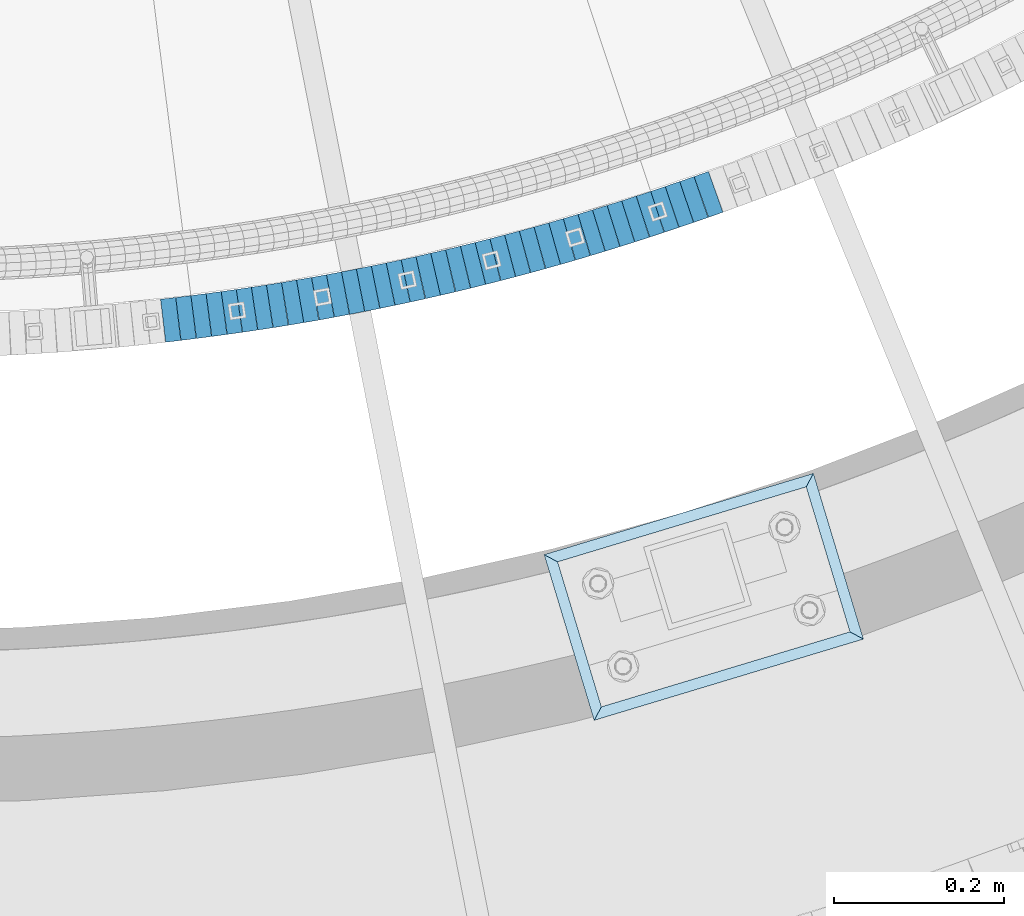
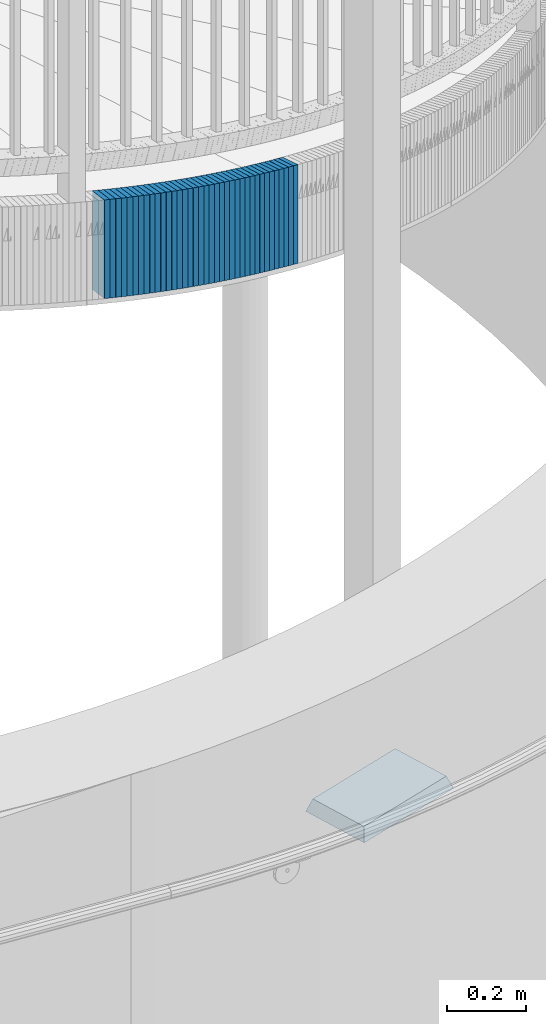
# One storey, part 878 of 975: 38 plates.
"""IFC2X3 building model written with IfcOpenShell, lengths in millimetres."""

from ifc_helpers import new_model, si_unit, frame, origin_with_axes, place, context, subcontext, project, spatial, faceted_brep, material, type_object, element, save


model = new_model("IFC2X3")

# Units and contexts
model_context = context("Model", 3, precision=1e-05, world=origin_with_axes())
body_context = subcontext(model_context, "Body", "Model", "MODEL_VIEW")
ifc_project = project(units=[si_unit("LENGTHUNIT", "METRE", prefix="MILLI"), si_unit("AREAUNIT", "SQUARE_METRE"), si_unit("VOLUMEUNIT", "CUBIC_METRE"), si_unit("MASSUNIT", "GRAM", prefix="KILO"), si_unit("TIMEUNIT", "SECOND"), si_unit("PLANEANGLEUNIT", "RADIAN"), si_unit("SOLIDANGLEUNIT", "STERADIAN"), si_unit("THERMODYNAMICTEMPERATUREUNIT", "DEGREE_CELSIUS"), si_unit("LUMINOUSINTENSITYUNIT", "LUMEN")], contexts=[model_context])

# Site, building, storey
site_placement = place(None, origin_with_axes())
site = spatial("IfcSite", under=ifc_project, at=site_placement, CompositionType="ELEMENT")
building_placement = place(site_placement, origin_with_axes())
building = spatial("IfcBuilding", under=site, at=building_placement, Name="Undefined", CompositionType="ELEMENT")
storey_placement = place(building_placement, origin_with_axes())
storey = spatial("IfcBuildingStorey", under=building, at=storey_placement, Name="Undefined", CompositionType="ELEMENT", Elevation=0.0)

# Plates
ifc_material_1 = material(Name="STEEL/A36")
plate_type_1 = type_object("IfcPlateType", PredefinedType="NOTDEFINED")
plate_1_placement = place(storey_placement, frame((35075.9674344348, 553.477183897986, 2953.7875000677), z_axis=(-0.993112467730433, -0.117164953968197, 0.0), x_axis=(0.0, 0.0, 1.0)))
element("IfcPlate", 1, at=plate_1_placement, inside=storey, type_object=plate_type_1, material=ifc_material_1, Name="WALL", context=body_context, shape_type="Brep", body=[
    faceted_brep([(0.0, -25.3999999999724, -1.81898940354586e-11), (5.69999980926514, -25.3999999999724, 17.9212169646999), (5.69999980926514, 25.3999999999651, 17.9212169647544), (0.0, 25.3999999999869, 1.45519152283669e-11), (310.5, -25.3999999999724, 17.9212169646999), (310.5, 25.3999999999651, 17.9212169647544), (304.799987792969, -25.3999999999724, -1.81898940354586e-11), (304.799987792969, 25.3999999999869, 1.45519152283669e-11)], [[[0, 1, 2, 3]], [[1, 4, 5, 2]], [[4, 6, 7, 5]], [[6, 0, 3, 7]], [[5, 7, 3, 2]], [[6, 4, 1, 0]]]),
])
plate_2_placement = place(storey_placement, frame((35093.9070637789, 555.694049108325, 2947.9875000677), z_axis=(-0.99244848307505, -0.122662172009276, 0.0), x_axis=(0.0, 0.0, 1.0)))
element("IfcPlate", 2, at=plate_2_placement, inside=storey, type_object=plate_type_1, material=ifc_material_1, Name="WALL", context=body_context, shape_type="Brep", body=[
    faceted_brep([(0.0, -25.3999999999724, -1.81898940354586e-11), (5.80000019073486, -25.3999999999614, 17.9424076079595), (5.80000019073486, 25.3999999999978, 17.9424076080322), (0.0, 25.3999999999869, 1.45519152283669e-11), (310.600006103516, -25.3999999999614, 17.9424076079595), (310.600006103516, 25.3999999999978, 17.9424076080322), (304.799987792969, -25.3999999999724, -1.81898940354586e-11), (304.799987792969, 25.3999999999869, 1.45519152283669e-11)], [[[0, 1, 2, 3]], [[1, 4, 5, 2]], [[4, 6, 7, 5]], [[6, 0, 3, 7]], [[5, 7, 3, 2]], [[6, 4, 1, 0]]]),
])
plate_3_placement = place(storey_placement, frame((35111.8464069323, 558.011662573431, 2942.1875000677), z_axis=(-0.99175503960636, -0.128148122949137, 0.0), x_axis=(0.0, 0.0, 1.0)))
element("IfcPlate", 3, at=plate_3_placement, inside=storey, type_object=plate_type_1, material=ifc_material_1, Name="WALL", context=body_context, shape_type="Brep", body=[
    faceted_brep([(0.0, -25.3999999999724, -1.81898940354586e-11), (5.80000019073486, -25.399999999976, 17.9493732452247), (5.80000019073486, 25.4000000000051, 17.9493732452393), (0.0, 25.3999999999869, 1.45519152283669e-11), (310.600006103516, -25.399999999976, 17.9493732452247), (310.600006103516, 25.4000000000051, 17.9493732452393), (304.799987792969, -25.3999999999724, -1.81898940354586e-11), (304.799987792969, 25.3999999999869, 1.45519152283669e-11)], [[[0, 1, 2, 3]], [[1, 4, 5, 2]], [[4, 6, 7, 5]], [[6, 0, 3, 7]], [[5, 7, 3, 2]], [[6, 4, 1, 0]]]),
])
plate_4_placement = place(storey_placement, frame((35129.7854519506, 560.430019497802, 2936.4875000677), z_axis=(-0.991032326071817, -0.133622336009683, 0.0), x_axis=(0.0, 0.0, 1.0)))
element("IfcPlate", 4, at=plate_4_placement, inside=storey, type_object=plate_type_1, material=ifc_material_1, Name="WALL", context=body_context, shape_type="Brep", body=[
    faceted_brep([(0.0, -25.3999999999724, -1.81898940354586e-11), (5.69999980926514, -25.400000000016, 17.9627399444762), (5.69999980926514, 25.3999999999869, 17.9627399444762), (0.0, 25.3999999999869, 1.45519152283669e-11), (310.5, -25.400000000016, 17.9627399444762), (310.5, 25.3999999999869, 17.9627399444762), (304.799987792969, -25.3999999999724, -1.81898940354586e-11), (304.799987792969, 25.3999999999869, 1.45519152283669e-11)], [[[0, 1, 2, 3]], [[1, 4, 5, 2]], [[4, 6, 7, 5]], [[6, 0, 3, 7]], [[5, 7, 3, 2]], [[6, 4, 1, 0]]]),
])
plate_5_placement = place(storey_placement, frame((35147.6437566702, 562.951871216824, 2930.7875000677), z_axis=(-0.990172022181619, -0.139854805025652, 0.0), x_axis=(0.0, 0.0, 1.0)))
element("IfcPlate", 5, at=plate_5_placement, inside=storey, type_object=plate_type_1, material=ifc_material_1, Name="WALL", context=body_context, shape_type="Brep", body=[
    faceted_brep([(0.0, -25.3999999999724, -1.81898940354586e-11), (5.69999980926514, -25.3999999999687, 17.8807163238307), (5.69999980926514, 25.400000000016, 17.880716323838), (0.0, 25.3999999999869, 1.45519152283669e-11), (310.5, -25.3999999999687, 17.8807163238307), (310.5, 25.400000000016, 17.880716323838), (304.799987792969, -25.3999999999724, -1.81898940354586e-11), (304.799987792969, 25.3999999999869, 1.45519152283669e-11)], [[[0, 1, 2, 3]], [[1, 4, 5, 2]], [[4, 6, 7, 5]], [[6, 0, 3, 7]], [[5, 7, 3, 2]], [[6, 4, 1, 0]]]),
])
plate_6_placement = place(storey_placement, frame((35165.4829044786, 565.571917777635, 2924.9875000677), z_axis=(-0.989382787518691, -0.145333064929299, 0.0), x_axis=(0.0, 0.0, 1.0)))
element("IfcPlate", 6, at=plate_6_placement, inside=storey, type_object=plate_type_1, material=ifc_material_1, Name="WALL", context=body_context, shape_type="Brep", body=[
    faceted_brep([(0.0, -25.3999999999724, -1.81898940354586e-11), (5.80000019073486, -25.4000000000451, 17.8891029358201), (5.80000019073486, 25.4000000000087, 17.8891029357856), (0.0, 25.3999999999869, 1.45519152283669e-11), (310.600006103516, -25.4000000000451, 17.8891029358201), (310.600006103516, 25.4000000000087, 17.8891029357856), (304.799987792969, -25.3999999999724, -1.81898940354586e-11), (304.799987792969, 25.3999999999869, 1.45519152283669e-11)], [[[0, 1, 2, 3]], [[1, 4, 5, 2]], [[4, 6, 7, 5]], [[6, 0, 3, 7]], [[5, 7, 3, 2]], [[6, 4, 1, 0]]]),
])
plate_7_placement = place(storey_placement, frame((35183.3217135676, 568.292699768361, 2919.2875000677), z_axis=(-0.988564598909017, -0.150797989986121, 0.0), x_axis=(0.0, 0.0, 1.0)))
element("IfcPlate", 7, at=plate_7_placement, inside=storey, type_object=plate_type_1, material=ifc_material_1, Name="WALL", context=body_context, shape_type="Brep", body=[
    faceted_brep([(0.0, -25.3999999999724, -1.81898940354586e-11), (5.69999980926514, -25.3999999999978, 17.9011173248218), (5.69999980926514, 25.4000000000087, 17.9011173248182), (0.0, 25.3999999999869, 1.45519152283669e-11), (310.5, -25.3999999999978, 17.9011173248218), (310.5, 25.4000000000087, 17.9011173248182), (304.799987792969, -25.3999999999724, -1.81898940354586e-11), (304.799987792969, 25.3999999999869, 1.45519152283669e-11)], [[[0, 1, 2, 3]], [[1, 4, 5, 2]], [[4, 6, 7, 5]], [[6, 0, 3, 7]], [[5, 7, 3, 2]], [[6, 4, 1, 0]]]),
])
plate_8_placement = place(storey_placement, frame((35201.1601723709, 571.11421156238, 2913.4875000677), z_axis=(-0.987717677908893, -0.156249123985588, 0.0), x_axis=(0.0, 0.0, 1.0)))
element("IfcPlate", 8, at=plate_8_placement, inside=storey, type_object=plate_type_1, material=ifc_material_1, Name="WALL", context=body_context, shape_type="Brep", body=[
    faceted_brep([(0.0, -25.3999999999724, -1.81898940354586e-11), (5.80000019073486, -25.4000000000233, 17.9178676605334), (5.80000019073486, 25.3999999999942, 17.9178676605297), (0.0, 25.3999999999869, 1.45519152283669e-11), (310.600006103516, -25.4000000000233, 17.9178676605334), (310.600006103516, 25.3999999999942, 17.9178676605297), (304.799987792969, -25.3999999999724, -1.81898940354586e-11), (304.799987792969, 25.3999999999869, 1.45519152283669e-11)], [[[0, 1, 2, 3]], [[1, 4, 5, 2]], [[4, 6, 7, 5]], [[6, 0, 3, 7]], [[5, 7, 3, 2]], [[6, 4, 1, 0]]]),
])
for number, where, z_axis, x_axis, name in (
    (9, (35219.0594313641, 574.163384992628, 2907.7875000677), (-0.985781716087097, -0.168030974014846, 0.0), (0.0, 0.0, 1.0), "WALL"),
    (10, (35236.6594313666, 577.163384993474, 2902.0875000677), (-0.985781716087097, -0.168030974014846, 0.0), (0.0, 0.0, 1.0), "WALL"),
):
    element("IfcPlate", number, at=place(storey_placement, frame(where, z_axis=z_axis, x_axis=x_axis)), inside=storey, type_object=plate_type_1, material=ifc_material_1, Name=name, context=body_context, shape_type="Brep", body=[
        faceted_brep([(0.0, -25.3999999999724, -1.81898940354586e-11), (5.69999980926514, -25.4000000000196, 17.8538513183848), (5.69999980926514, 25.4000000000415, 17.8538513183157), (0.0, 25.3999999999869, 1.45519152283669e-11), (310.5, -25.4000000000196, 17.8538513183848), (310.5, 25.4000000000415, 17.8538513183157), (304.799987792969, -25.3999999999724, -1.81898940354586e-11), (304.799987792969, 25.3999999999869, 1.45519152283669e-11)], [[[0, 1, 2, 3]], [[1, 4, 5, 2]], [[4, 6, 7, 5]], [[6, 0, 3, 7]], [[5, 7, 3, 2]], [[6, 4, 1, 0]]]),
    ])
plate_9_placement = place(storey_placement, frame((35254.5351347612, 580.411944865235, 2896.2875000677), z_axis=(-0.983869910131907, -0.178885438023983, 0.0), x_axis=(0.0, 0.0, 1.0)))
element("IfcPlate", 11, at=plate_9_placement, inside=storey, type_object=plate_type_1, material=ifc_material_1, Name="WALL", context=body_context, shape_type="Brep", body=[
    faceted_brep([(0.0, -25.3999999999724, -1.81898940354586e-11), (5.80000019073486, -25.4000000000451, 17.8891029358201), (5.80000019073486, 25.4000000000087, 17.8891029357856), (0.0, 25.3999999999869, 1.45519152283669e-11), (310.600006103516, -25.4000000000451, 17.8891029358201), (310.600006103516, 25.4000000000087, 17.8891029357856), (304.799987792969, -25.3999999999724, -1.81898940354586e-11), (304.799987792969, 25.3999999999869, 1.45519152283669e-11)], [[[0, 1, 2, 3]], [[1, 4, 5, 2]], [[4, 6, 7, 5]], [[6, 0, 3, 7]], [[5, 7, 3, 2]], [[6, 4, 1, 0]]]),
])
plate_10_placement = place(storey_placement, frame((35272.2723734305, 583.737287034992, 2890.5875000677), z_axis=(-0.982872186945643, -0.184288534989808, 0.0), x_axis=(0.0, 0.0, 1.0)))
element("IfcPlate", 12, at=plate_10_placement, inside=storey, type_object=plate_type_1, material=ifc_material_1, Name="WALL", context=body_context, shape_type="Brep", body=[
    faceted_brep([(0.0, -25.3999999999724, -1.81898940354586e-11), (5.69999980926514, -25.4000000000633, 17.9075393677485), (5.69999980926514, 25.3999999999905, 17.9075393676903), (0.0, 25.3999999999869, 1.45519152283669e-11), (310.5, -25.4000000000633, 17.9075393677485), (310.5, 25.3999999999905, 17.9075393676903), (304.799987792969, -25.3999999999724, -1.81898940354586e-11), (304.799987792969, 25.3999999999869, 1.45519152283669e-11)], [[[0, 1, 2, 3]], [[1, 4, 5, 2]], [[4, 6, 7, 5]], [[6, 0, 3, 7]], [[5, 7, 3, 2]], [[6, 4, 1, 0]]]),
])
plate_11_placement = place(storey_placement, frame((35289.9357203773, 587.168468453887, 2884.8875000677), z_axis=(-0.98164457204821, -0.190719517009368, 0.0), x_axis=(0.0, 0.0, 1.0)))
element("IfcPlate", 13, at=plate_11_placement, inside=storey, type_object=plate_type_1, material=ifc_material_1, Name="WALL", context=body_context, shape_type="Brep", body=[
    faceted_brep([(0.0, -25.3999999999724, -1.81898940354586e-11), (5.69999980926514, -25.3999999999724, 17.833955764745), (5.69999980926514, 25.3999999999905, 17.8339557647923), (0.0, 25.3999999999869, 1.45519152283669e-11), (310.5, -25.3999999999724, 17.833955764745), (310.5, 25.3999999999905, 17.8339557647923), (304.799987792969, -25.3999999999724, -1.81898940354586e-11), (304.799987792969, 25.3999999999869, 1.45519152283669e-11)], [[[0, 1, 2, 3]], [[1, 4, 5, 2]], [[4, 6, 7, 5]], [[6, 0, 3, 7]], [[5, 7, 3, 2]], [[6, 4, 1, 0]]]),
])
plate_12_placement = place(storey_placement, frame((35307.5727944738, 590.695491420504, 2879.0875000677), z_axis=(-0.980580675729382, -0.196116134945876, 0.0), x_axis=(0.0, 0.0, 1.0)))
element("IfcPlate", 14, at=plate_12_placement, inside=storey, type_object=plate_type_1, material=ifc_material_1, Name="WALL", context=body_context, shape_type="Brep", body=[
    faceted_brep([(0.0, -25.3999999999724, -1.81898940354586e-11), (5.80000019073486, -25.4000000000306, 17.853010177645), (5.80000019073486, 25.3999999999578, 17.8530101776596), (0.0, 25.3999999999869, 1.45519152283669e-11), (310.600006103516, -25.4000000000306, 17.853010177645), (310.600006103516, 25.3999999999578, 17.8530101776596), (304.799987792969, -25.3999999999724, -1.81898940354586e-11), (304.799987792969, 25.3999999999869, 1.45519152283669e-11)], [[[0, 1, 2, 3]], [[1, 4, 5, 2]], [[4, 6, 7, 5]], [[6, 0, 3, 7]], [[5, 7, 3, 2]], [[6, 4, 1, 0]]]),
])
plate_13_placement = place(storey_placement, frame((35325.2094174322, 594.323206148735, 2873.3875000677), z_axis=(-0.979489544723104, -0.20149499194304, 0.0), x_axis=(0.0, 0.0, 1.0)))
element("IfcPlate", 15, at=plate_13_placement, inside=storey, type_object=plate_type_1, material=ifc_material_1, Name="WALL", context=body_context, shape_type="Brep", body=[
    faceted_brep([(0.0, -25.3999999999724, -1.81898940354586e-11), (5.69999980926514, -25.3999999999469, 17.8731651305425), (5.69999980926514, 25.3999999999869, 17.8731651306334), (0.0, 25.3999999999869, 1.45519152283669e-11), (310.5, -25.3999999999469, 17.8731651305425), (310.5, 25.3999999999869, 17.8731651306334), (304.799987792969, -25.3999999999724, -1.81898940354586e-11), (304.799987792969, 25.3999999999869, 1.45519152283669e-11)], [[[0, 1, 2, 3]], [[1, 4, 5, 2]], [[4, 6, 7, 5]], [[6, 0, 3, 7]], [[5, 7, 3, 2]], [[6, 4, 1, 0]]]),
])
plate_14_placement = place(storey_placement, frame((35342.8455789443, 598.051605330564, 2867.6875000677), z_axis=(-0.978371466698947, -0.206855681936349, 0.0), x_axis=(0.0, 0.0, 1.0)))
element("IfcPlate", 16, at=plate_14_placement, inside=storey, type_object=plate_type_1, material=ifc_material_1, Name="WALL", context=body_context, shape_type="Brep", body=[
    faceted_brep([(0.0, -25.3999999999724, -1.81898940354586e-11), (5.69999980926514, -25.3999999999614, 17.8921775817616), (5.69999980926514, 25.400000000016, 17.8921775817726), (0.0, 25.3999999999869, 1.45519152283669e-11), (310.5, -25.3999999999614, 17.8921775817616), (310.5, 25.400000000016, 17.8921775817726), (304.799987792969, -25.3999999999724, -1.81898940354586e-11), (304.799987792969, 25.3999999999869, 1.45519152283669e-11)], [[[0, 1, 2, 3]], [[1, 4, 5, 2]], [[4, 6, 7, 5]], [[6, 0, 3, 7]], [[5, 7, 3, 2]], [[6, 4, 1, 0]]]),
])
plate_15_placement = place(storey_placement, frame((35360.4108385813, 601.887120817719, 2861.9875000677), z_axis=(-0.97697321919279, -0.213361967042104, 0.0), x_axis=(0.0, 0.0, 1.0)))
element("IfcPlate", 17, at=plate_15_placement, inside=storey, type_object=plate_type_1, material=ifc_material_1, Name="WALL", context=body_context, shape_type="Brep", body=[
    faceted_brep([(0.0, -25.3999999999724, -1.81898940354586e-11), (5.69999980926514, -25.4000000000306, 17.8058986664291), (5.69999980926514, 25.4000000000415, 17.80589866632), (0.0, 25.3999999999869, 1.45519152283669e-11), (310.5, -25.4000000000306, 17.8058986664291), (310.5, 25.4000000000415, 17.80589866632), (304.799987792969, -25.3999999999724, -1.81898940354586e-11), (304.799987792969, 25.3999999999869, 1.45519152283669e-11)], [[[0, 1, 2, 3]], [[1, 4, 5, 2]], [[4, 6, 7, 5]], [[6, 0, 3, 7]], [[5, 7, 3, 2]], [[6, 4, 1, 0]]]),
])
plate_16_placement = place(storey_placement, frame((35378.0820936038, 605.947917447558, 2856.1875000677), z_axis=(-0.974579651097025, -0.224041299022304, 0.0), x_axis=(0.0, 0.0, 1.0)))
element("IfcPlate", 18, at=plate_16_placement, inside=storey, type_object=plate_type_1, material=ifc_material_1, Name="WALL", context=body_context, shape_type="Brep", body=[
    faceted_brep([(0.0, -25.3999999999724, -1.81898940354586e-11), (5.80000019073486, -25.4000000000306, 17.853010177645), (5.80000019073486, 25.3999999999578, 17.8530101776596), (0.0, 25.3999999999869, 1.45519152283669e-11), (310.600006103516, -25.4000000000306, 17.853010177645), (310.600006103516, 25.3999999999578, 17.8530101776596), (304.799987792969, -25.3999999999724, -1.81898940354586e-11), (304.799987792969, 25.3999999999869, 1.45519152283669e-11)], [[[0, 1, 2, 3]], [[1, 4, 5, 2]], [[4, 6, 7, 5]], [[6, 0, 3, 7]], [[5, 7, 3, 2]], [[6, 4, 1, 0]]]),
])
plate_17_placement = place(storey_placement, frame((35395.4820935939, 609.9479174478, 2850.4875000677), z_axis=(-0.974579651097025, -0.224041299022304, 0.0), x_axis=(0.0, 0.0, 1.0)))
element("IfcPlate", 19, at=plate_17_placement, inside=storey, type_object=plate_type_1, material=ifc_material_1, Name="WALL", context=body_context, shape_type="Brep", body=[
    faceted_brep([(0.0, -25.3999999999724, -1.81898940354586e-11), (5.69999980926514, -25.4000000000196, 17.8538513183848), (5.69999980926514, 25.4000000000415, 17.8538513183157), (0.0, 25.3999999999869, 1.45519152283669e-11), (310.5, -25.4000000000196, 17.8538513183848), (310.5, 25.4000000000415, 17.8538513183157), (304.799987792969, -25.3999999999724, -1.81898940354586e-11), (304.799987792969, 25.3999999999869, 1.45519152283669e-11)], [[[0, 1, 2, 3]], [[1, 4, 5, 2]], [[4, 6, 7, 5]], [[6, 0, 3, 7]], [[5, 7, 3, 2]], [[6, 4, 1, 0]]]),
])
plate_18_placement = place(storey_placement, frame((35413.1513141428, 614.211352487403, 2844.7875000677), z_axis=(-0.972082208620478, -0.234640532908391, 0.0), x_axis=(0.0, 0.0, 1.0)))
element("IfcPlate", 20, at=plate_18_placement, inside=storey, type_object=plate_type_1, material=ifc_material_1, Name="WALL", context=body_context, shape_type="Brep", body=[
    faceted_brep([(0.0, -25.3999999999724, -1.81898940354586e-11), (5.69999980926514, -25.3999999999978, 17.9011173248218), (5.69999980926514, 25.4000000000087, 17.9011173248182), (0.0, 25.3999999999869, 1.45519152283669e-11), (310.5, -25.3999999999978, 17.9011173248218), (310.5, 25.4000000000087, 17.9011173248182), (304.799987792969, -25.3999999999724, -1.81898940354586e-11), (304.799987792969, 25.3999999999869, 1.45519152283669e-11)], [[[0, 1, 2, 3]], [[1, 4, 5, 2]], [[4, 6, 7, 5]], [[6, 0, 3, 7]], [[5, 7, 3, 2]], [[6, 4, 1, 0]]]),
])
plate_19_placement = place(storey_placement, frame((35430.6183177916, 618.552262394646, 2839.0875000677), z_axis=(-0.970471582358486, -0.241215480089104, 0.0), x_axis=(0.0, 0.0, 1.0)))
element("IfcPlate", 21, at=plate_19_placement, inside=storey, type_object=plate_type_1, material=ifc_material_1, Name="WALL", context=body_context, shape_type="Brep", body=[
    faceted_brep([(0.0, -25.3999999999724, -1.81898940354586e-11), (5.69999980926514, -25.3999999999724, 17.833955764745), (5.69999980926514, 25.3999999999905, 17.8339557647923), (0.0, 25.3999999999869, 1.45519152283669e-11), (310.5, -25.3999999999724, 17.833955764745), (310.5, 25.3999999999905, 17.8339557647923), (304.799987792969, -25.3999999999724, -1.81898940354586e-11), (304.799987792969, 25.3999999999869, 1.45519152283669e-11)], [[[0, 1, 2, 3]], [[1, 4, 5, 2]], [[4, 6, 7, 5]], [[6, 0, 3, 7]], [[5, 7, 3, 2]], [[6, 4, 1, 0]]]),
])
plate_20_placement = place(storey_placement, frame((35448.1184256767, 622.977360760553, 2833.2875000677), z_axis=(-0.969483457737362, -0.245156735933585, 0.0), x_axis=(0.0, 0.0, 1.0)))
element("IfcPlate", 22, at=plate_20_placement, inside=storey, type_object=plate_type_1, material=ifc_material_1, Name="WALL", context=body_context, shape_type="Brep", body=[
    faceted_brep([(0.0, -25.3999999999724, -1.81898940354586e-11), (5.80000019073486, -25.399999999976, 17.9493732452247), (5.80000019073486, 25.4000000000051, 17.9493732452393), (0.0, 25.3999999999869, 1.45519152283669e-11), (310.600006103516, -25.399999999976, 17.9493732452247), (310.600006103516, 25.4000000000051, 17.9493732452393), (304.799987792969, -25.3999999999724, -1.81898940354586e-11), (304.799987792969, 25.3999999999869, 1.45519152283669e-11)], [[[0, 1, 2, 3]], [[1, 4, 5, 2]], [[4, 6, 7, 5]], [[6, 0, 3, 7]], [[5, 7, 3, 2]], [[6, 4, 1, 0]]]),
])
plate_21_placement = place(storey_placement, frame((35465.520406478, 627.529319536101, 2827.5875000677), z_axis=(-0.967437836661998, -0.253108735911569, 0.0), x_axis=(0.0, 0.0, 1.0)))
element("IfcPlate", 23, at=plate_21_placement, inside=storey, type_object=plate_type_1, material=ifc_material_1, Name="WALL", context=body_context, shape_type="Brep", body=[
    faceted_brep([(0.0, -25.3999999999724, -1.81898940354586e-11), (5.69999980926514, -25.3999999999869, 17.7789192200216), (5.69999980926514, 25.3999999999851, 17.7789192199052), (0.0, 25.3999999999869, 1.45519152283669e-11), (310.5, -25.3999999999869, 17.7789192200216), (310.5, 25.3999999999851, 17.7789192199052), (304.799987792969, -25.3999999999724, -1.81898940354586e-11), (304.799987792969, 25.3999999999869, 1.45519152283669e-11)], [[[0, 1, 2, 3]], [[1, 4, 5, 2]], [[4, 6, 7, 5]], [[6, 0, 3, 7]], [[5, 7, 3, 2]], [[6, 4, 1, 0]]]),
])
plate_22_placement = place(storey_placement, frame((35482.9184114876, 632.155169417149, 2821.8875000677), z_axis=(-0.966420124809233, -0.256967200949276, 0.0), x_axis=(0.0, 0.0, 1.0)))
element("IfcPlate", 24, at=plate_22_placement, inside=storey, type_object=plate_type_1, material=ifc_material_1, Name="WALL", context=body_context, shape_type="Brep", body=[
    faceted_brep([(0.0, -25.3999999999724, -1.81898940354586e-11), (5.69999980926514, -25.3999999999978, 17.9011173248218), (5.69999980926514, 25.4000000000087, 17.9011173248182), (0.0, 25.3999999999869, 1.45519152283669e-11), (310.5, -25.3999999999978, 17.9011173248218), (310.5, 25.4000000000087, 17.9011173248182), (304.799987792969, -25.3999999999724, -1.81898940354586e-11), (304.799987792969, 25.3999999999869, 1.45519152283669e-11)], [[[0, 1, 2, 3]], [[1, 4, 5, 2]], [[4, 6, 7, 5]], [[6, 0, 3, 7]], [[5, 7, 3, 2]], [[6, 4, 1, 0]]]),
])
plate_23_placement = place(storey_placement, frame((35500.2866795082, 636.900529844537, 2816.0875000677), z_axis=(-0.96463428122535, -0.263591926061579, 0.0), x_axis=(0.0, 0.0, 1.0)))
element("IfcPlate", 25, at=plate_23_placement, inside=storey, type_object=plate_type_1, material=ifc_material_1, Name="WALL", context=body_context, shape_type="Brep", body=[
    faceted_brep([(0.0, -25.3999999999724, -1.81898940354586e-11), (5.80000019073486, -25.3999999999796, 17.8280677795228), (5.80000019073486, 25.4000000000196, 17.8280677795265), (0.0, 25.3999999999869, 1.45519152283669e-11), (310.600006103516, -25.3999999999796, 17.8280677795228), (310.600006103516, 25.4000000000196, 17.8280677795265), (304.799987792969, -25.3999999999724, -1.81898940354586e-11), (304.799987792969, 25.3999999999869, 1.45519152283669e-11)], [[[0, 1, 2, 3]], [[1, 4, 5, 2]], [[4, 6, 7, 5]], [[6, 0, 3, 7]], [[5, 7, 3, 2]], [[6, 4, 1, 0]]]),
])
plate_24_placement = place(storey_placement, frame((35517.8133704641, 641.863604331133, 2810.3875000677), z_axis=(-0.962151033748204, -0.272516766928682, 0.0), x_axis=(0.0, 0.0, 1.0)))
element("IfcPlate", 26, at=plate_24_placement, inside=storey, type_object=plate_type_1, material=ifc_material_1, Name="WALL", context=body_context, shape_type="Brep", body=[
    faceted_brep([(0.0, -25.3999999999724, -1.81898940354586e-11), (5.69999980926514, -25.4000000000233, 17.9805450439708), (5.69999980926514, 25.4000000000124, 17.9805450439344), (0.0, 25.3999999999869, 1.45519152283669e-11), (310.5, -25.4000000000233, 17.9805450439708), (310.5, 25.4000000000124, 17.9805450439344), (304.799987792969, -25.3999999999724, -1.81898940354586e-11), (304.799987792969, 25.3999999999869, 1.45519152283669e-11)], [[[0, 1, 2, 3]], [[1, 4, 5, 2]], [[4, 6, 7, 5]], [[6, 0, 3, 7]], [[5, 7, 3, 2]], [[6, 4, 1, 0]]]),
])
plate_25_placement = place(storey_placement, frame((35534.9882183811, 646.784927949119, 2804.6875000677), z_axis=(-0.96131152122974, -0.27546353506583, 0.0), x_axis=(0.0, 0.0, 1.0)))
element("IfcPlate", 27, at=plate_25_placement, inside=storey, type_object=plate_type_1, material=ifc_material_1, Name="WALL", context=body_context, shape_type="Brep", body=[
    faceted_brep([(0.0, -25.3999999999724, -1.81898940354586e-11), (5.69999980926514, -25.4000000000251, 17.7924137116061), (5.69999980926514, 25.4000000000051, 17.7924137115479), (0.0, 25.3999999999869, 1.45519152283669e-11), (310.5, -25.4000000000251, 17.7924137116061), (310.5, 25.4000000000051, 17.7924137115479), (304.799987792969, -25.3999999999724, -1.81898940354586e-11), (304.799987792969, 25.3999999999869, 1.45519152283669e-11)], [[[0, 1, 2, 3]], [[1, 4, 5, 2]], [[4, 6, 7, 5]], [[6, 0, 3, 7]], [[5, 7, 3, 2]], [[6, 4, 1, 0]]]),
])
plate_26_placement = place(storey_placement, frame((35552.4121085815, 651.950197318042, 2798.8875000677), z_axis=(-0.958741861067632, -0.284278110020053, 0.0), x_axis=(0.0, 0.0, 1.0)))
element("IfcPlate", 28, at=plate_26_placement, inside=storey, type_object=plate_type_1, material=ifc_material_1, Name="WALL", context=body_context, shape_type="Brep", body=[
    faceted_brep([(0.0, -25.3999999999724, -1.81898940354586e-11), (5.80000019073486, -25.3999999999614, 17.9424076079595), (5.80000019073486, 25.3999999999978, 17.9424076080322), (0.0, 25.3999999999869, 1.45519152283669e-11), (310.600006103516, -25.3999999999614, 17.9424076079595), (310.600006103516, 25.3999999999978, 17.9424076080322), (304.799987792969, -25.3999999999724, -1.81898940354586e-11), (304.799987792969, 25.3999999999869, 1.45519152283669e-11)], [[[0, 1, 2, 3]], [[1, 4, 5, 2]], [[4, 6, 7, 5]], [[6, 0, 3, 7]], [[5, 7, 3, 2]], [[6, 4, 1, 0]]]),
])
plate_27_placement = place(storey_placement, frame((35569.6812944179, 657.201003596779, 2793.1875000677), z_axis=(-0.956741613892852, -0.290938969967417, 0.0), x_axis=(0.0, 0.0, 1.0)))
element("IfcPlate", 29, at=plate_27_placement, inside=storey, type_object=plate_type_1, material=ifc_material_1, Name="WALL", context=body_context, shape_type="Brep", body=[
    faceted_brep([(0.0, -25.3999999999724, -1.81898940354586e-11), (5.69999980926514, -25.3999999999469, 17.8731651305425), (5.69999980926514, 25.3999999999869, 17.8731651306334), (0.0, 25.3999999999869, 1.45519152283669e-11), (310.5, -25.3999999999469, 17.8731651305425), (310.5, 25.3999999999869, 17.8731651306334), (304.799987792969, -25.3999999999724, -1.81898940354586e-11), (304.799987792969, 25.3999999999869, 1.45519152283669e-11)], [[[0, 1, 2, 3]], [[1, 4, 5, 2]], [[4, 6, 7, 5]], [[6, 0, 3, 7]], [[5, 7, 3, 2]], [[6, 4, 1, 0]]]),
])
plate_28_placement = place(storey_placement, frame((35586.9110589564, 662.54084327431, 2787.3875000677), z_axis=(-0.95517312266217, -0.296047809895292, 0.0), x_axis=(0.0, 0.0, 1.0)))
element("IfcPlate", 30, at=plate_28_placement, inside=storey, type_object=plate_type_1, material=ifc_material_1, Name="WALL", context=body_context, shape_type="Brep", body=[
    faceted_brep([(0.0, -25.3999999999724, -1.81898940354586e-11), (5.80000019073486, -25.399999999936, 17.9011173247382), (5.80000019073486, 25.3999999999578, 17.9011173248837), (0.0, 25.3999999999869, 1.45519152283669e-11), (310.600006103516, -25.399999999936, 17.9011173247382), (310.600006103516, 25.3999999999578, 17.9011173248837), (304.799987792969, -25.3999999999724, -1.81898940354586e-11), (304.799987792969, 25.3999999999869, 1.45519152283669e-11)], [[[0, 1, 2, 3]], [[1, 4, 5, 2]], [[4, 6, 7, 5]], [[6, 0, 3, 7]], [[5, 7, 3, 2]], [[6, 4, 1, 0]]]),
])
plate_29_placement = place(storey_placement, frame((35604.1401813385, 667.981240896981, 2781.6875000677), z_axis=(-0.953582665103915, -0.301131368032814, 0.0), x_axis=(0.0, 0.0, 1.0)))
element("IfcPlate", 31, at=plate_29_placement, inside=storey, type_object=plate_type_1, material=ifc_material_1, Name="WALL", context=body_context, shape_type="Brep", body=[
    faceted_brep([(0.0, -25.3999999999724, -1.81898940354586e-11), (5.69999980926514, -25.3999999999896, 17.9334888457815), (5.69999980926514, 25.3999999999869, 17.9334888458907), (0.0, 25.3999999999869, 1.45519152283669e-11), (310.5, -25.3999999999896, 17.9334888457815), (310.5, 25.3999999999869, 17.9334888458907), (304.799987792969, -25.3999999999724, -1.81898940354586e-11), (304.799987792969, 25.3999999999869, 1.45519152283669e-11)], [[[0, 1, 2, 3]], [[1, 4, 5, 2]], [[4, 6, 7, 5]], [[6, 0, 3, 7]], [[5, 7, 3, 2]], [[6, 4, 1, 0]]]),
])
plate_30_placement = place(storey_placement, frame((35621.3686548584, 673.52218682113, 2775.9875000677), z_axis=(-0.951970620864683, -0.306189380956477, 0.0), x_axis=(0.0, 0.0, 1.0)))
element("IfcPlate", 32, at=plate_30_placement, inside=storey, type_object=plate_type_1, material=ifc_material_1, Name="WALL", context=body_context, shape_type="Brep", body=[
    faceted_brep([(0.0, -25.3999999999724, -1.81898940354586e-11), (5.69999980926514, -25.400000000016, 17.9627399444762), (5.69999980926514, 25.3999999999869, 17.9627399444762), (0.0, 25.3999999999869, 1.45519152283669e-11), (310.5, -25.400000000016, 17.9627399444762), (310.5, 25.3999999999869, 17.9627399444762), (304.799987792969, -25.3999999999724, -1.81898940354586e-11), (304.799987792969, 25.3999999999869, 1.45519152283669e-11)], [[[0, 1, 2, 3]], [[1, 4, 5, 2]], [[4, 6, 7, 5]], [[6, 0, 3, 7]], [[5, 7, 3, 2]], [[6, 4, 1, 0]]]),
])
plate_31_placement = place(storey_placement, frame((35638.5384333825, 679.177453153164, 2770.1875000677), z_axis=(-0.949794781024638, -0.312873575008116, 0.0), x_axis=(0.0, 0.0, 1.0)))
element("IfcPlate", 33, at=plate_31_placement, inside=storey, type_object=plate_type_1, material=ifc_material_1, Name="WALL", context=body_context, shape_type="Brep", body=[
    faceted_brep([(0.0, -25.3999999999724, -1.81898940354586e-11), (5.80000019073486, -25.399999999936, 17.9011173247382), (5.80000019073486, 25.3999999999578, 17.9011173248837), (0.0, 25.3999999999869, 1.45519152283669e-11), (310.600006103516, -25.399999999936, 17.9011173247382), (310.600006103516, 25.3999999999578, 17.9011173248837), (304.799987792969, -25.3999999999724, -1.81898940354586e-11), (304.799987792969, 25.3999999999869, 1.45519152283669e-11)], [[[0, 1, 2, 3]], [[1, 4, 5, 2]], [[4, 6, 7, 5]], [[6, 0, 3, 7]], [[5, 7, 3, 2]], [[6, 4, 1, 0]]]),
])
plate_32_placement = place(storey_placement, frame((35655.6661156011, 684.91988838302, 2764.3875000677), z_axis=(-0.948124102702791, -0.317900433900346, 0.0), x_axis=(0.0, 0.0, 1.0)))
element("IfcPlate", 34, at=plate_32_placement, inside=storey, type_object=plate_type_1, material=ifc_material_1, Name="WALL", context=body_context, shape_type="Brep", body=[
    faceted_brep([(0.0, -25.3999999999724, -1.81898940354586e-11), (5.80000019073486, -25.3999999999833, 17.9287471770986), (5.80000019073486, 25.4000000000087, 17.9287471771167), (0.0, 25.3999999999869, 1.45519152283669e-11), (310.600006103516, -25.3999999999833, 17.9287471770986), (310.600006103516, 25.4000000000087, 17.9287471771167), (304.799987792969, -25.3999999999724, -1.81898940354586e-11), (304.799987792969, 25.3999999999869, 1.45519152283669e-11)], [[[0, 1, 2, 3]], [[1, 4, 5, 2]], [[4, 6, 7, 5]], [[6, 0, 3, 7]], [[5, 7, 3, 2]], [[6, 4, 1, 0]]]),
])
plate_33_placement = place(storey_placement, frame((35672.7931205287, 690.762845598698, 2758.6875000677), z_axis=(-0.946432873739402, -0.322900627911091, 0.0), x_axis=(0.0, 0.0, 1.0)))
element("IfcPlate", 35, at=plate_33_placement, inside=storey, type_object=plate_type_1, material=ifc_material_1, Name="WALL", context=body_context, shape_type="Brep", body=[
    faceted_brep([(0.0, -25.3999999999724, -1.81898940354586e-11), (5.69999980926514, -25.400000000016, 17.9627399444762), (5.69999980926514, 25.3999999999869, 17.9627399444762), (0.0, 25.3999999999869, 1.45519152283669e-11), (310.5, -25.400000000016, 17.9627399444762), (310.5, 25.3999999999869, 17.9627399444762), (304.799987792969, -25.3999999999724, -1.81898940354586e-11), (304.799987792969, 25.3999999999869, 1.45519152283669e-11)], [[[0, 1, 2, 3]], [[1, 4, 5, 2]], [[4, 6, 7, 5]], [[6, 0, 3, 7]], [[5, 7, 3, 2]], [[6, 4, 1, 0]]]),
])
plate_34_placement = place(storey_placement, frame((35689.7365508538, 696.577706827114, 2752.9875000677), z_axis=(-0.945847786021473, -0.324610483007371, 0.0), x_axis=(0.0, 0.0, 1.0)))
element("IfcPlate", 36, at=plate_34_placement, inside=storey, type_object=plate_type_1, material=ifc_material_1, Name="WALL", context=body_context, shape_type="Brep", body=[
    faceted_brep([(0.0, -25.3999999999724, -1.81898940354586e-11), (5.69999980926514, -25.3999999999469, 17.8731651305425), (5.69999980926514, 25.3999999999869, 17.8731651306334), (0.0, 25.3999999999869, 1.45519152283669e-11), (310.5, -25.3999999999469, 17.8731651305425), (310.5, 25.3999999999869, 17.8731651306334), (304.799987792969, -25.3999999999724, -1.81898940354586e-11), (304.799987792969, 25.3999999999869, 1.45519152283669e-11)], [[[0, 1, 2, 3]], [[1, 4, 5, 2]], [[4, 6, 7, 5]], [[6, 0, 3, 7]], [[5, 7, 3, 2]], [[6, 4, 1, 0]]]),
])
plate_35_placement = place(storey_placement, frame((35706.8895124427, 702.6660161069, 2747.1875000677), z_axis=(-0.942371042718134, -0.334569600899928, 0.0), x_axis=(0.0, 0.0, 1.0)))
element("IfcPlate", 37, at=plate_35_placement, inside=storey, type_object=plate_type_1, material=ifc_material_1, Name="WALL", context=body_context, shape_type="Brep", body=[
    faceted_brep([(0.0, -25.3999999999724, -1.81898940354586e-11), (5.80000019073486, -25.3999999999833, 17.9287471770986), (5.80000019073486, 25.4000000000087, 17.9287471771167), (0.0, 25.3999999999869, 1.45519152283669e-11), (310.600006103516, -25.3999999999833, 17.9287471770986), (310.600006103516, 25.4000000000087, 17.9287471771167), (304.799987792969, -25.3999999999724, -1.81898940354586e-11), (304.799987792969, 25.3999999999869, 1.45519152283669e-11)], [[[0, 1, 2, 3]], [[1, 4, 5, 2]], [[4, 6, 7, 5]], [[6, 0, 3, 7]], [[5, 7, 3, 2]], [[6, 4, 1, 0]]]),
])
ifc_material_2 = material(Name="CONCRETE/GROUT")
plate_type_2 = type_object("IfcPlateType", PredefinedType="NOTDEFINED")
plate_36_placement = place(storey_placement, frame((35821.6262339593, 372.152907582998, 1390.65), z_axis=(0.288864709123643, -0.957369928409553, 0.0), x_axis=(-0.957369928409554, -0.288864709123642, 0.0)))
element("IfcPlate", 38, at=plate_36_placement, inside=storey, type_object=plate_type_2, material=ifc_material_2, Name="GROUT", context=body_context, shape_type="Brep", body=[
    faceted_brep([(330.200012367033, 19.0500013667977, 203.199997417756), (1.09139364212751e-11, 19.05, 203.199996948282), (12.7000000020234, -19.0499999844749, 190.500000003405), (317.500000003602, -19.049999999379, 190.499999996773), (330.200012206657, 19.0500004884277, -1.48389517562464e-07), (317.499999999585, -19.0499999999586, 12.6999999966938), (12.6999999980108, -19.0499999989649, 12.7000000033258), (2.63382389675826e-07, 19.0500000000138, 0.0)], [[[0, 1, 2, 3]], [[4, 5, 6, 7]], [[5, 4, 0, 3]], [[6, 5, 3, 2]], [[7, 6, 2, 1]], [[4, 7, 1, 0]]]),
])

save(model, "model.ifc")
